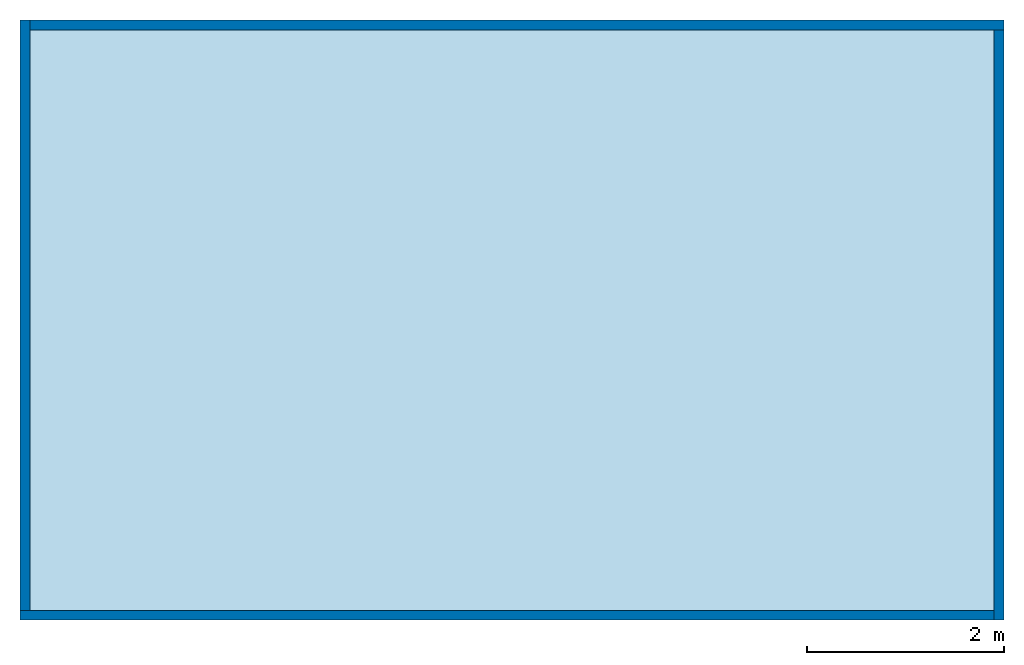
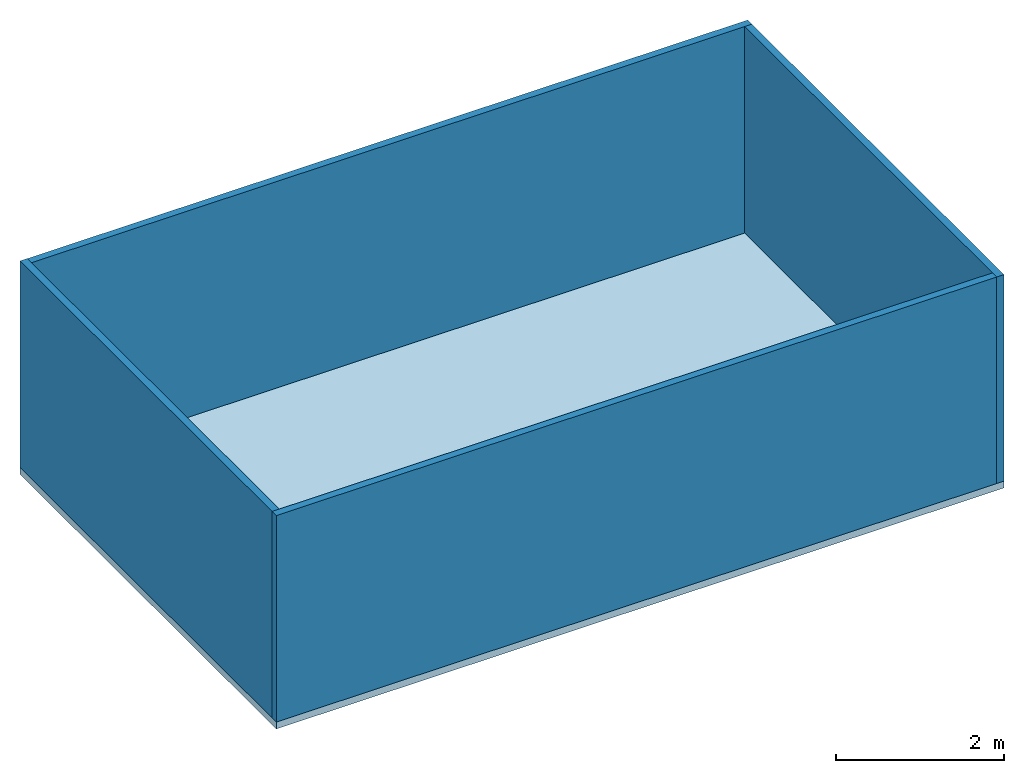
# One storey: 4 walls, 1 slab.
"""IFC4 building model written with IfcOpenShell, lengths in metres."""

from ifc_helpers import new_model, entity, si_unit, converted_unit, frame, origin_with_axes, origin_2d_with_axis, place, context, subcontext, project, spatial, line, indexed_curve, outline, extrude, material, layer, layer_set, layer_usage, type_object, element, save


model = new_model("IFC4")

# Units and contexts
model_context = context("Model", 3, precision=1e-05, world=origin_with_axes())
plan_context = context("Plan", 2, precision=1e-05, world=origin_2d_with_axis())
body_context = subcontext(model_context, "Body", "Model", "MODEL_VIEW")
ifc_project = project(units=[converted_unit("PLANEANGLEUNIT", "degree", entity("IfcReal", 0.0174532925199433), si_unit("PLANEANGLEUNIT", "RADIAN"), dimensions=[0, 0, 0, 0, 0, 0, 0]), si_unit("AREAUNIT", "SQUARE_METRE"), si_unit("VOLUMEUNIT", "CUBIC_METRE"), si_unit("LENGTHUNIT", "METRE")], contexts=[model_context, plan_context])

# Site, building, storey
site_placement = place(None, origin_with_axes())
site = spatial("IfcSite", under=ifc_project, at=site_placement)
building_placement = place(site_placement, origin_with_axes())
building = spatial("IfcBuilding", under=site, at=building_placement, Name="Building")
storey_placement = place(building_placement, origin_with_axes())
storey = spatial("IfcBuildingStorey", under=building, at=storey_placement, Name="Planta 0")

# Slab
ifc_material = material()
ifc_layer_1 = layer(ifc_material, 0.1)
ifc_layer_set_1 = layer_set([ifc_layer_1])
ifc_layer_usage_1 = layer_usage(ifc_layer_set_1, "AXIS3", "POSITIVE", 0.0)
slab_type = type_object("IfcSlabType", PredefinedType="FLOOR", material=ifc_layer_set_1)
slab_placement = place(storey_placement, frame((0.0, 0.0, -0.100000001490116), z_axis=(0.0, 0.0, 1.0), x_axis=(1.0, 0.0, 0.0)))
element("IfcSlab", 1, at=slab_placement, inside=storey, type_object=slab_type, material=ifc_layer_usage_1, Name="Slab", context=body_context, shape_type="SweptSolid", body=[
    extrude(outline(indexed_curve([(0.0, 0.0), (10.0, 0.0), (9.99999904632568, 6.09999990463257), (0.0, 6.09999847412109)], segments=[line(3, 2), line(2, 1), line(1, 4), line(4, 3)], self_intersect=False)), None, (0.0, 0.0, 1.0), 0.1),
])

# Walls
ifc_layer_2 = layer(ifc_material, 0.1)
ifc_layer_set_2 = layer_set([ifc_layer_2])
ifc_layer_usage_2 = layer_usage(ifc_layer_set_2, "AXIS2", "POSITIVE", 0.0)
wall_type = type_object("IfcWallType", PredefinedType="SOLIDWALL", material=ifc_layer_set_2)
wall_1_placement = place(storey_placement, origin_with_axes())
element("IfcWall", 2, at=wall_1_placement, inside=storey, type_object=wall_type, material=ifc_layer_usage_2, Name="Wall", context=body_context, shape_type="SweptSolid", body=[
    extrude(outline(indexed_curve([(0.0, 0.0), (0.0, 0.1), (9.89999972256747, 0.1), (9.89999972256747, 0.0), (0.0, 0.0)], self_intersect=False)), origin_with_axes(), (0.0, 0.0, 1.0), 3.0),
])
ifc_layer_usage_3 = layer_usage(ifc_layer_set_2, "AXIS2", "POSITIVE", 0.0)
wall_2_placement = place(storey_placement, frame((10.0, 0.0, 0.0), z_axis=(0.0, 0.0, 1.0), x_axis=(-1.62920684942944e-07, 0.999999999999987, 0.0)))
element("IfcWall", 3, at=wall_2_placement, inside=storey, type_object=wall_type, material=ifc_layer_usage_3, Name="Wall", context=body_context, shape_type="SweptSolid", body=[
    extrude(outline(indexed_curve([(0.0, 0.0), (0.0, 0.1), (6.00000000000008, 0.1), (6.00000000000008, 0.0), (0.0, 0.0)], self_intersect=False)), origin_with_axes(), (0.0, 0.0, 1.0), 3.0),
])
ifc_layer_usage_4 = layer_usage(ifc_layer_set_2, "AXIS2", "POSITIVE", 0.0)
wall_3_placement = place(storey_placement, frame((9.99999904632568, 6.09999990463257, 0.0), z_axis=(0.0, 0.0, 1.0), x_axis=(-0.999999999999989, -1.50995802528085e-07, 0.0)))
element("IfcWall", 4, at=wall_3_placement, inside=storey, type_object=wall_type, material=ifc_layer_usage_4, Name="Wall", context=body_context, shape_type="SweptSolid", body=[
    extrude(outline(indexed_curve([(0.0, 0.0), (0.0, 0.1), (9.89999972256757, 0.1), (9.89999972256757, 0.0), (0.0, 0.0)], self_intersect=False)), origin_with_axes(), (0.0, 0.0, 1.0), 3.0),
])
ifc_layer_usage_5 = layer_usage(ifc_layer_set_2, "AXIS2", "POSITIVE", 0.0)
wall_4_placement = place(storey_placement, frame((-5.73694705963135e-07, 6.09999847412109, 0.0), z_axis=(0.0, 0.0, 1.0), x_axis=(3.13916473260163e-07, -0.999999999999951, 0.0)))
element("IfcWall", 5, at=wall_4_placement, inside=storey, type_object=wall_type, material=ifc_layer_usage_5, Name="Wall", context=body_context, shape_type="SweptSolid", body=[
    extrude(outline(indexed_curve([(0.0, 0.0), (0.0, 0.1), (6.0000000000003, 0.1), (6.0000000000003, 0.0), (0.0, 0.0)], self_intersect=False)), origin_with_axes(), (0.0, 0.0, 1.0), 3.0),
])

save(model, "model.ifc")
